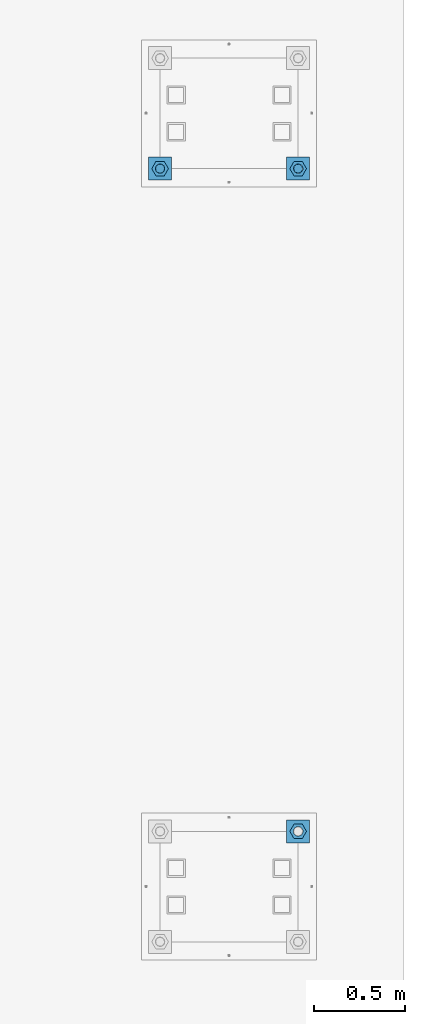
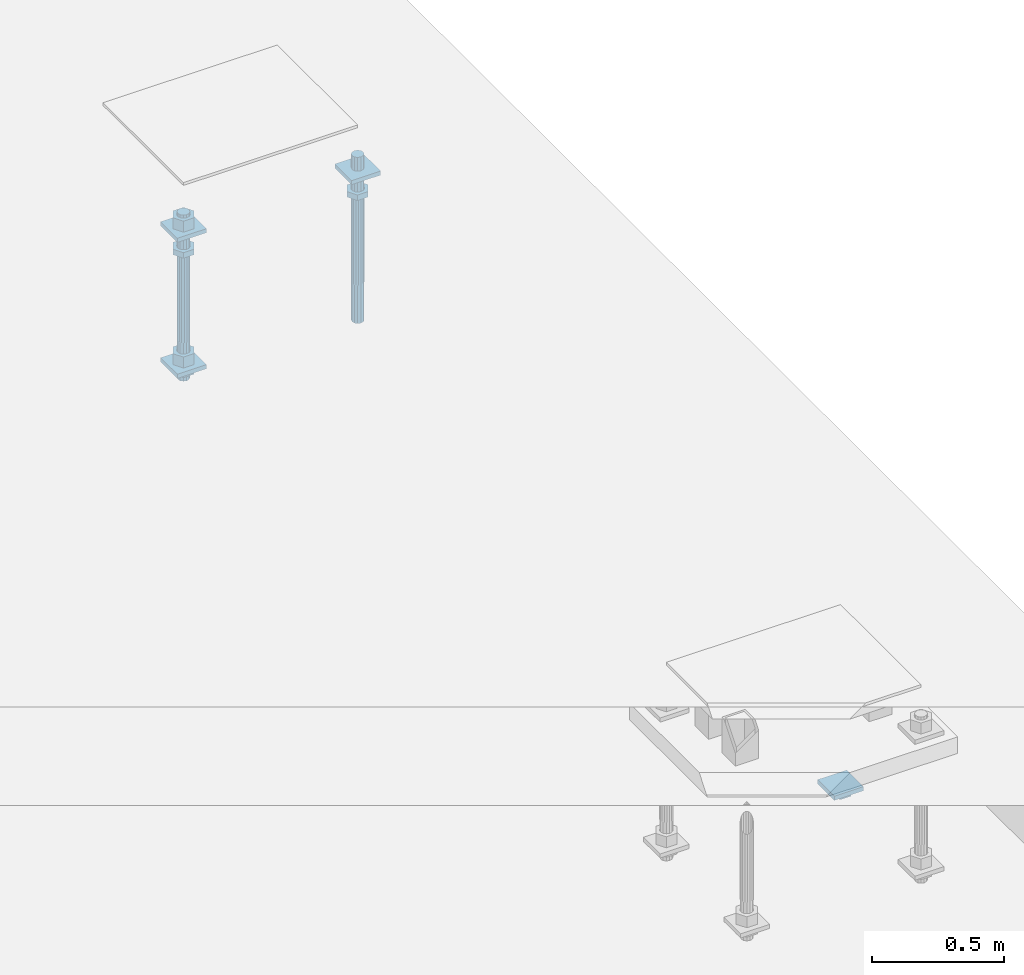
# One storey, part 2636 of 3843: 12 beams, 2 elements without a shape of their own.
"""IFC2X3 building model written with IfcOpenShell, lengths in millimetres."""

from ifc_helpers import new_model, si_unit, frame, origin_with_axes, place, context, subcontext, project, spatial, faceted_brep, material, type_object, element, aggregate, save


model = new_model("IFC2X3")

# Units and contexts
model_context = context("Model", 3, precision=1e-05, world=origin_with_axes())
body_context = subcontext(model_context, "Body", "Model", "MODEL_VIEW")
ifc_project = project(units=[si_unit("LENGTHUNIT", "METRE", prefix="MILLI"), si_unit("AREAUNIT", "SQUARE_METRE"), si_unit("VOLUMEUNIT", "CUBIC_METRE"), si_unit("MASSUNIT", "GRAM", prefix="KILO"), si_unit("TIMEUNIT", "SECOND"), si_unit("PLANEANGLEUNIT", "RADIAN"), si_unit("SOLIDANGLEUNIT", "STERADIAN"), si_unit("THERMODYNAMICTEMPERATUREUNIT", "DEGREE_CELSIUS"), si_unit("LUMINOUSINTENSITYUNIT", "LUMEN")], contexts=[model_context])

# Site, building, storey
site_placement = place(None, origin_with_axes())
site = spatial("IfcSite", under=ifc_project, at=site_placement, CompositionType="ELEMENT")
building_placement = place(site_placement, origin_with_axes())
building = spatial("IfcBuilding", under=site, at=building_placement, Name="Undefined", CompositionType="ELEMENT")
storey_placement = place(building_placement, origin_with_axes())
storey = spatial("IfcBuildingStorey", under=building, at=storey_placement, Name="Undefined", CompositionType="ELEMENT", Elevation=0.0)

# Assembly, beams
assembly_1_placement = place(storey_placement, origin_with_axes())
assembly_1 = element("IfcElementAssembly", 1, at=assembly_1_placement, inside=storey, Name="TEMPLATE", AssemblyPlace="NOTDEFINED", PredefinedType="RIGID_FRAME")
ifc_material_1 = material(Name="STEEL/A572-50")
beam_type_1 = type_object("IfcBeamType", PredefinedType="NOTDEFINED")
beam_1_placement = place(assembly_1_placement, frame((118465.6, 7086.60000152587, 29873.575), z_axis=(1.0, 0.0, 0.0), x_axis=(0.0, 1.0, 0.0)))
beam_1 = element("IfcBeam", 2, at=beam_1_placement, type_object=beam_type_1, material=ifc_material_1, Name="WASHER_PLATE", context=body_context, shape_type="Brep", body=[
    faceted_brep([(0.0, 9.52500000000146, -63.5), (0.0, 9.52500000000146, 63.5), (127.0, 9.52500000000146, 63.5), (127.0, 9.52500000000146, -63.5), (0.0, -9.52500000000146, 63.5), (127.0, -9.52500000000146, 63.5), (0.0, -9.52500000000146, -63.5), (127.0, -9.52500000000146, -63.5)], [[[0, 1, 2, 3]], [[1, 4, 5, 2]], [[4, 6, 7, 5]], [[6, 0, 3, 7]], [[5, 7, 3, 2]], [[6, 4, 1, 0]]]),
])
beam_2_placement = place(assembly_1_placement, frame((119227.6, 7086.60000152587, 29873.575), z_axis=(1.0, 0.0, 0.0), x_axis=(0.0, 1.0, 0.0)))
beam_2 = element("IfcBeam", 3, at=beam_2_placement, type_object=beam_type_1, material=ifc_material_1, Name="WASHER_PLATE", context=body_context, shape_type="Brep", body=[
    faceted_brep([(0.0, 9.52500000000146, -63.5), (0.0, 9.52500000000146, 63.5), (127.0, 9.52500000000146, 63.5), (127.0, 9.52500000000146, -63.5), (0.0, -9.52500000000146, 63.5), (127.0, -9.52500000000146, 63.5), (0.0, -9.52500000000146, -63.5), (127.0, -9.52500000000146, -63.5)], [[[0, 1, 2, 3]], [[1, 4, 5, 2]], [[4, 6, 7, 5]], [[6, 0, 3, 7]], [[5, 7, 3, 2]], [[6, 4, 1, 0]]]),
])
beam_3_placement = place(assembly_1_placement, frame((118465.6, 7086.60000152587, 29244.925), z_axis=(1.0, 0.0, 0.0), x_axis=(0.0, 1.0, 0.0)))
beam_3 = element("IfcBeam", 4, at=beam_3_placement, type_object=beam_type_1, material=ifc_material_1, Name="WASHER_PLATE", context=body_context, shape_type="Brep", body=[
    faceted_brep([(0.0, 9.52500000000146, -63.5), (0.0, 9.52500000000146, 63.5), (127.0, 9.52500000000146, 63.5), (127.0, 9.52500000000146, -63.5), (0.0, -9.52500000000146, 63.5), (127.0, -9.52500000000146, 63.5), (0.0, -9.52500000000146, -63.5), (127.0, -9.52500000000146, -63.5)], [[[0, 1, 2, 3]], [[1, 4, 5, 2]], [[4, 6, 7, 5]], [[6, 0, 3, 7]], [[5, 7, 3, 2]], [[6, 4, 1, 0]]]),
])

# Assembly, beam
assembly_2_placement = place(storey_placement, origin_with_axes())
assembly_2 = element("IfcElementAssembly", 5, at=assembly_2_placement, inside=storey, Name="TEMPLATE", AssemblyPlace="NOTDEFINED", PredefinedType="RIGID_FRAME")
beam_4_placement = place(assembly_2_placement, frame((119227.6, 3429.00000152587, 29244.925), z_axis=(1.0, 0.0, 0.0), x_axis=(0.0, 1.0, 0.0)))
beam_4 = element("IfcBeam", 6, at=beam_4_placement, type_object=beam_type_1, material=ifc_material_1, Name="WASHER_PLATE", context=body_context, shape_type="Brep", body=[
    faceted_brep([(0.0, 9.52500000000146, -63.5), (0.0, 9.52500000000146, 63.5), (127.0, 9.52500000000146, 63.5), (127.0, 9.52500000000146, -63.5), (0.0, -9.52500000000146, 63.5), (127.0, -9.52500000000146, 63.5), (0.0, -9.52500000000146, -63.5), (127.0, -9.52500000000146, -63.5)], [[[0, 1, 2, 3]], [[1, 4, 5, 2]], [[4, 6, 7, 5]], [[6, 0, 3, 7]], [[5, 7, 3, 2]], [[6, 4, 1, 0]]]),
])

# Beam
ifc_material_2 = material(Name="STEEL/A36")
beam_type_2 = type_object("IfcBeamType", Name="2_HALF_NUT", PredefinedType="NOTDEFINED")
beam_5_placement = place(assembly_1_placement, frame((118465.6, 7150.10000152587, 29787.85), z_axis=(0.0, 1.0, 0.0), x_axis=(0.0, 0.0, -1.0)))
beam_5 = element("IfcBeam", 7, at=beam_5_placement, type_object=beam_type_2, material=ifc_material_2, Name="NUT", ObjectType="2_HALF_NUT", context=body_context, shape_type="Brep", body=[
    faceted_brep([(0.0, -46.0369987487793, 0.0), (0.0, -23.0184993743896, -39.869213104248), (25.4000000000015, -23.0184993743896, -39.869213104248), (25.4000000000015, -46.0369987487793, 0.0), (0.0, 23.0184993743896, -39.869213104248), (25.4000000000015, 23.0184993743896, -39.869213104248), (0.0, 46.0369987487793, 0.0), (25.4000000000015, 46.0369987487793, 0.0), (0.0, 23.0184993743896, 39.869213104248), (25.4000000000015, 23.0184993743896, 39.869213104248), (0.0, -23.0184993743896, 39.869213104248), (25.4000000000015, -23.0184993743896, 39.869213104248), (0.0, 0.0, 26.1940002441406), (0.0, 11.3650617044477, 23.5999013092805), (25.4000000000015, 11.3650617044477, 23.5999013092805), (25.4000000000015, 0.0, 26.1940002441406), (0.0, 20.4791109456419, 16.3316083006721), (25.4000000000015, 20.4791109456419, 16.3316083006721), (0.0, 25.5370200498292, 5.82867859874386), (25.4000000000015, 25.5370200498292, 5.82867859874386), (0.0, 25.5370200498292, -5.82867859874386), (25.4000000000015, 25.5370200498292, -5.82867859874386), (0.0, 20.4791109456419, -16.3316083006721), (25.4000000000015, 20.4791109456419, -16.3316083006721), (0.0, 11.3650617044477, -23.5999013092805), (25.4000000000015, 11.3650617044477, -23.5999013092805), (0.0, 0.0, -26.1940002441406), (25.4000000000015, 0.0, -26.1940002441406), (0.0, -11.3650617044477, -23.5999013092805), (25.4000000000015, -11.3650617044477, -23.5999013092805), (0.0, -20.4791109456419, -16.3316083006721), (25.4000000000015, -20.4791109456419, -16.3316083006721), (0.0, -25.5370200498292, -5.82867859874386), (25.4000000000015, -25.5370200498292, -5.82867859874386), (0.0, -25.5370200498292, 5.82867859874386), (25.4000000000015, -25.5370200498292, 5.82867859874386), (0.0, -20.4791109456419, 16.3316083006721), (25.4000000000015, -20.4791109456419, 16.3316083006721), (0.0, -11.3650617044477, 23.5999013092805), (25.4000000000015, -11.3650617044477, 23.5999013092805)], [[[0, 1, 2, 3]], [[1, 4, 5, 2]], [[4, 6, 7, 5]], [[6, 8, 9, 7]], [[8, 10, 11, 9]], [[10, 0, 3, 11]], [[12, 13, 14, 15]], [[13, 16, 17, 14]], [[16, 18, 19, 17]], [[18, 20, 21, 19]], [[20, 22, 23, 21]], [[22, 24, 25, 23]], [[24, 26, 27, 25]], [[26, 28, 29, 27]], [[28, 30, 31, 29]], [[30, 32, 33, 31]], [[32, 34, 35, 33]], [[34, 36, 37, 35]], [[36, 38, 39, 37]], [[38, 12, 15, 39]], [[5, 7, 9, 11, 3, 2], [17, 19, 21, 23, 25, 27, 29, 31, 33, 35, 37, 39, 15, 14]], [[10, 8, 6, 4, 1, 0], [38, 36, 34, 32, 30, 28, 26, 24, 22, 20, 18, 16, 13, 12]]]),
])

beam_6_placement = place(assembly_1_placement, frame((118465.6, 7150.10000152587, 29235.4), z_axis=(0.0, 1.0, 0.0), x_axis=(0.0, 0.0, -1.0)))
beam_6 = element("IfcBeam", 8, at=beam_6_placement, type_object=beam_type_2, material=ifc_material_2, Name="NUT", ObjectType="2_HALF_NUT", context=body_context, shape_type="Brep", body=[
    faceted_brep([(0.0, -46.0369987487793, 0.0), (0.0, -23.0184993743896, -39.869213104248), (25.4000000000015, -23.0184993743896, -39.869213104248), (25.4000000000015, -46.0369987487793, 0.0), (0.0, 23.0184993743896, -39.869213104248), (25.4000000000015, 23.0184993743896, -39.869213104248), (0.0, 46.0369987487793, 0.0), (25.4000000000015, 46.0369987487793, 0.0), (0.0, 23.0184993743896, 39.869213104248), (25.4000000000015, 23.0184993743896, 39.869213104248), (0.0, -23.0184993743896, 39.869213104248), (25.4000000000015, -23.0184993743896, 39.869213104248), (0.0, 0.0, 26.1940002441406), (0.0, 11.3650617044477, 23.5999013092805), (25.4000000000015, 11.3650617044477, 23.5999013092805), (25.4000000000015, 0.0, 26.1940002441406), (0.0, 20.4791109456419, 16.3316083006721), (25.4000000000015, 20.4791109456419, 16.3316083006721), (0.0, 25.5370200498292, 5.82867859874386), (25.4000000000015, 25.5370200498292, 5.82867859874386), (0.0, 25.5370200498292, -5.82867859874386), (25.4000000000015, 25.5370200498292, -5.82867859874386), (0.0, 20.4791109456419, -16.3316083006721), (25.4000000000015, 20.4791109456419, -16.3316083006721), (0.0, 11.3650617044477, -23.5999013092805), (25.4000000000015, 11.3650617044477, -23.5999013092805), (0.0, 0.0, -26.1940002441406), (25.4000000000015, 0.0, -26.1940002441406), (0.0, -11.3650617044477, -23.5999013092805), (25.4000000000015, -11.3650617044477, -23.5999013092805), (0.0, -20.4791109456419, -16.3316083006721), (25.4000000000015, -20.4791109456419, -16.3316083006721), (0.0, -25.5370200498292, -5.82867859874386), (25.4000000000015, -25.5370200498292, -5.82867859874386), (0.0, -25.5370200498292, 5.82867859874386), (25.4000000000015, -25.5370200498292, 5.82867859874386), (0.0, -20.4791109456419, 16.3316083006721), (25.4000000000015, -20.4791109456419, 16.3316083006721), (0.0, -11.3650617044477, 23.5999013092805), (25.4000000000015, -11.3650617044477, 23.5999013092805)], [[[0, 1, 2, 3]], [[1, 4, 5, 2]], [[4, 6, 7, 5]], [[6, 8, 9, 7]], [[8, 10, 11, 9]], [[10, 0, 3, 11]], [[12, 13, 14, 15]], [[13, 16, 17, 14]], [[16, 18, 19, 17]], [[18, 20, 21, 19]], [[20, 22, 23, 21]], [[22, 24, 25, 23]], [[24, 26, 27, 25]], [[26, 28, 29, 27]], [[28, 30, 31, 29]], [[30, 32, 33, 31]], [[32, 34, 35, 33]], [[34, 36, 37, 35]], [[36, 38, 39, 37]], [[38, 12, 15, 39]], [[5, 7, 9, 11, 3, 2], [17, 19, 21, 23, 25, 27, 29, 31, 33, 35, 37, 39, 15, 14]], [[10, 8, 6, 4, 1, 0], [38, 36, 34, 32, 30, 28, 26, 24, 22, 20, 18, 16, 13, 12]]]),
])

beam_7_placement = place(assembly_1_placement, frame((119227.6, 7150.10000152587, 29787.85), z_axis=(0.0, 1.0, 0.0), x_axis=(0.0, 0.0, -1.0)))
beam_7 = element("IfcBeam", 9, at=beam_7_placement, type_object=beam_type_2, material=ifc_material_2, Name="NUT", ObjectType="2_HALF_NUT", context=body_context, shape_type="Brep", body=[
    faceted_brep([(0.0, -46.0369987487793, 0.0), (0.0, -23.0184993743896, -39.869213104248), (25.4000000000015, -23.0184993743896, -39.869213104248), (25.4000000000015, -46.0369987487793, 0.0), (0.0, 23.0184993743896, -39.869213104248), (25.4000000000015, 23.0184993743896, -39.869213104248), (0.0, 46.0369987487793, 0.0), (25.4000000000015, 46.0369987487793, 0.0), (0.0, 23.0184993743896, 39.869213104248), (25.4000000000015, 23.0184993743896, 39.869213104248), (0.0, -23.0184993743896, 39.869213104248), (25.4000000000015, -23.0184993743896, 39.869213104248), (0.0, 0.0, 26.1940002441406), (0.0, 11.3650617044477, 23.5999013092805), (25.4000000000015, 11.3650617044477, 23.5999013092805), (25.4000000000015, 0.0, 26.1940002441406), (0.0, 20.4791109456419, 16.3316083006721), (25.4000000000015, 20.4791109456419, 16.3316083006721), (0.0, 25.5370200498292, 5.82867859874386), (25.4000000000015, 25.5370200498292, 5.82867859874386), (0.0, 25.5370200498292, -5.82867859874386), (25.4000000000015, 25.5370200498292, -5.82867859874386), (0.0, 20.4791109456419, -16.3316083006721), (25.4000000000015, 20.4791109456419, -16.3316083006721), (0.0, 11.3650617044477, -23.5999013092805), (25.4000000000015, 11.3650617044477, -23.5999013092805), (0.0, 0.0, -26.1940002441406), (25.4000000000015, 0.0, -26.1940002441406), (0.0, -11.3650617044477, -23.5999013092805), (25.4000000000015, -11.3650617044477, -23.5999013092805), (0.0, -20.4791109456419, -16.3316083006721), (25.4000000000015, -20.4791109456419, -16.3316083006721), (0.0, -25.5370200498292, -5.82867859874386), (25.4000000000015, -25.5370200498292, -5.82867859874386), (0.0, -25.5370200498292, 5.82867859874386), (25.4000000000015, -25.5370200498292, 5.82867859874386), (0.0, -20.4791109456419, 16.3316083006721), (25.4000000000015, -20.4791109456419, 16.3316083006721), (0.0, -11.3650617044477, 23.5999013092805), (25.4000000000015, -11.3650617044477, 23.5999013092805)], [[[0, 1, 2, 3]], [[1, 4, 5, 2]], [[4, 6, 7, 5]], [[6, 8, 9, 7]], [[8, 10, 11, 9]], [[10, 0, 3, 11]], [[12, 13, 14, 15]], [[13, 16, 17, 14]], [[16, 18, 19, 17]], [[18, 20, 21, 19]], [[20, 22, 23, 21]], [[22, 24, 25, 23]], [[24, 26, 27, 25]], [[26, 28, 29, 27]], [[28, 30, 31, 29]], [[30, 32, 33, 31]], [[32, 34, 35, 33]], [[34, 36, 37, 35]], [[36, 38, 39, 37]], [[38, 12, 15, 39]], [[5, 7, 9, 11, 3, 2], [17, 19, 21, 23, 25, 27, 29, 31, 33, 35, 37, 39, 15, 14]], [[10, 8, 6, 4, 1, 0], [38, 36, 34, 32, 30, 28, 26, 24, 22, 20, 18, 16, 13, 12]]]),
])

beam_8_placement = place(assembly_2_placement, frame((119227.6, 3492.50000152587, 29235.4), z_axis=(0.0, 1.0, 0.0), x_axis=(0.0, 0.0, -1.0)))
beam_8 = element("IfcBeam", 10, at=beam_8_placement, type_object=beam_type_2, material=ifc_material_2, Name="NUT", ObjectType="2_HALF_NUT", context=body_context, shape_type="Brep", body=[
    faceted_brep([(0.0, -46.0369987487793, 0.0), (0.0, -23.0184993743896, -39.869213104248), (25.4000000000015, -23.0184993743896, -39.869213104248), (25.4000000000015, -46.0369987487793, 0.0), (0.0, 23.0184993743896, -39.869213104248), (25.4000000000015, 23.0184993743896, -39.869213104248), (0.0, 46.0369987487793, 0.0), (25.4000000000015, 46.0369987487793, 0.0), (0.0, 23.0184993743896, 39.869213104248), (25.4000000000015, 23.0184993743896, 39.869213104248), (0.0, -23.0184993743896, 39.869213104248), (25.4000000000015, -23.0184993743896, 39.869213104248), (0.0, 0.0, 26.1940002441406), (0.0, 11.3650617044477, 23.5999013092805), (25.4000000000015, 11.3650617044477, 23.5999013092805), (25.4000000000015, 0.0, 26.1940002441406), (0.0, 20.4791109456419, 16.3316083006721), (25.4000000000015, 20.4791109456419, 16.3316083006721), (0.0, 25.5370200498292, 5.82867859874386), (25.4000000000015, 25.5370200498292, 5.82867859874386), (0.0, 25.5370200498292, -5.82867859874386), (25.4000000000015, 25.5370200498292, -5.82867859874386), (0.0, 20.4791109456419, -16.3316083006721), (25.4000000000015, 20.4791109456419, -16.3316083006721), (0.0, 11.3650617044477, -23.5999013092805), (25.4000000000015, 11.3650617044477, -23.5999013092805), (0.0, 0.0, -26.1940002441406), (25.4000000000015, 0.0, -26.1940002441406), (0.0, -11.3650617044477, -23.5999013092805), (25.4000000000015, -11.3650617044477, -23.5999013092805), (0.0, -20.4791109456419, -16.3316083006721), (25.4000000000015, -20.4791109456419, -16.3316083006721), (0.0, -25.5370200498292, -5.82867859874386), (25.4000000000015, -25.5370200498292, -5.82867859874386), (0.0, -25.5370200498292, 5.82867859874386), (25.4000000000015, -25.5370200498292, 5.82867859874386), (0.0, -20.4791109456419, 16.3316083006721), (25.4000000000015, -20.4791109456419, 16.3316083006721), (0.0, -11.3650617044477, 23.5999013092805), (25.4000000000015, -11.3650617044477, 23.5999013092805)], [[[0, 1, 2, 3]], [[1, 4, 5, 2]], [[4, 6, 7, 5]], [[6, 8, 9, 7]], [[8, 10, 11, 9]], [[10, 0, 3, 11]], [[12, 13, 14, 15]], [[13, 16, 17, 14]], [[16, 18, 19, 17]], [[18, 20, 21, 19]], [[20, 22, 23, 21]], [[22, 24, 25, 23]], [[24, 26, 27, 25]], [[26, 28, 29, 27]], [[28, 30, 31, 29]], [[30, 32, 33, 31]], [[32, 34, 35, 33]], [[34, 36, 37, 35]], [[36, 38, 39, 37]], [[38, 12, 15, 39]], [[5, 7, 9, 11, 3, 2], [17, 19, 21, 23, 25, 27, 29, 31, 33, 35, 37, 39, 15, 14]], [[10, 8, 6, 4, 1, 0], [38, 36, 34, 32, 30, 28, 26, 24, 22, 20, 18, 16, 13, 12]]]),
])

aggregate(assembly_2, [beam_8, beam_4])

beam_type_3 = type_object("IfcBeamType", Name="2_HEAVY_HEX_NUT", PredefinedType="NOTDEFINED")
beam_9_placement = place(assembly_1_placement, frame((118465.6, 7150.10000152587, 29933.9), z_axis=(0.0, 1.0, 0.0), x_axis=(0.0, 0.0, -1.0)))
beam_9 = element("IfcBeam", 11, at=beam_9_placement, type_object=beam_type_3, material=ifc_material_2, Name="NUT", ObjectType="2_HEAVY_HEX_NUT", context=body_context, shape_type="Brep", body=[
    faceted_brep([(0.0, -46.0369987487793, 0.0), (0.0, -23.0184993743896, -39.869213104248), (50.7999999999993, -23.0184993743896, -39.869213104248), (50.7999999999993, -46.0369987487793, 0.0), (0.0, 23.0184993743896, -39.869213104248), (50.7999999999993, 23.0184993743896, -39.869213104248), (0.0, 46.0369987487793, 0.0), (50.7999999999993, 46.0369987487793, 0.0), (0.0, 23.0184993743896, 39.869213104248), (50.7999999999993, 23.0184993743896, 39.869213104248), (0.0, -23.0184993743896, 39.869213104248), (50.7999999999993, -23.0184993743896, 39.869213104248), (0.0, 0.0, 26.1940002441406), (0.0, 11.3650617044477, 23.5999013092805), (50.7999999999993, 11.3650617044477, 23.5999013092805), (50.7999999999993, 0.0, 26.1940002441406), (0.0, 20.4791109456419, 16.3316083006721), (50.7999999999993, 20.4791109456419, 16.3316083006721), (0.0, 25.5370200498292, 5.82867859874386), (50.7999999999993, 25.5370200498292, 5.82867859874386), (0.0, 25.5370200498292, -5.82867859874386), (50.7999999999993, 25.5370200498292, -5.82867859874386), (0.0, 20.4791109456419, -16.3316083006721), (50.7999999999993, 20.4791109456419, -16.3316083006721), (0.0, 11.3650617044477, -23.5999013092805), (50.7999999999993, 11.3650617044477, -23.5999013092805), (0.0, 0.0, -26.1940002441406), (50.7999999999993, 0.0, -26.1940002441406), (0.0, -11.3650617044477, -23.5999013092805), (50.7999999999993, -11.3650617044477, -23.5999013092805), (0.0, -20.4791109456419, -16.3316083006721), (50.7999999999993, -20.4791109456419, -16.3316083006721), (0.0, -25.5370200498292, -5.82867859874386), (50.7999999999993, -25.5370200498292, -5.82867859874386), (0.0, -25.5370200498292, 5.82867859874386), (50.7999999999993, -25.5370200498292, 5.82867859874386), (0.0, -20.4791109456419, 16.3316083006721), (50.7999999999993, -20.4791109456419, 16.3316083006721), (0.0, -11.3650617044477, 23.5999013092805), (50.7999999999993, -11.3650617044477, 23.5999013092805)], [[[0, 1, 2, 3]], [[1, 4, 5, 2]], [[4, 6, 7, 5]], [[6, 8, 9, 7]], [[8, 10, 11, 9]], [[10, 0, 3, 11]], [[12, 13, 14, 15]], [[13, 16, 17, 14]], [[16, 18, 19, 17]], [[18, 20, 21, 19]], [[20, 22, 23, 21]], [[22, 24, 25, 23]], [[24, 26, 27, 25]], [[26, 28, 29, 27]], [[28, 30, 31, 29]], [[30, 32, 33, 31]], [[32, 34, 35, 33]], [[34, 36, 37, 35]], [[36, 38, 39, 37]], [[38, 12, 15, 39]], [[5, 7, 9, 11, 3, 2], [17, 19, 21, 23, 25, 27, 29, 31, 33, 35, 37, 39, 15, 14]], [[10, 8, 6, 4, 1, 0], [38, 36, 34, 32, 30, 28, 26, 24, 22, 20, 18, 16, 13, 12]]]),
])

beam_10_placement = place(assembly_1_placement, frame((118465.6, 7150.10000152587, 29305.25), z_axis=(0.0, 1.0, 0.0), x_axis=(0.0, 0.0, -1.0)))
beam_10 = element("IfcBeam", 12, at=beam_10_placement, type_object=beam_type_3, material=ifc_material_2, Name="NUT", ObjectType="2_HEAVY_HEX_NUT", context=body_context, shape_type="Brep", body=[
    faceted_brep([(0.0, -46.0369987487793, 0.0), (0.0, -23.0184993743896, -39.869213104248), (50.7999999999993, -23.0184993743896, -39.869213104248), (50.7999999999993, -46.0369987487793, 0.0), (0.0, 23.0184993743896, -39.869213104248), (50.7999999999993, 23.0184993743896, -39.869213104248), (0.0, 46.0369987487793, 0.0), (50.7999999999993, 46.0369987487793, 0.0), (0.0, 23.0184993743896, 39.869213104248), (50.7999999999993, 23.0184993743896, 39.869213104248), (0.0, -23.0184993743896, 39.869213104248), (50.7999999999993, -23.0184993743896, 39.869213104248), (0.0, 0.0, 26.1940002441406), (0.0, 11.3650617044477, 23.5999013092805), (50.7999999999993, 11.3650617044477, 23.5999013092805), (50.7999999999993, 0.0, 26.1940002441406), (0.0, 20.4791109456419, 16.3316083006721), (50.7999999999993, 20.4791109456419, 16.3316083006721), (0.0, 25.5370200498292, 5.82867859874386), (50.7999999999993, 25.5370200498292, 5.82867859874386), (0.0, 25.5370200498292, -5.82867859874386), (50.7999999999993, 25.5370200498292, -5.82867859874386), (0.0, 20.4791109456419, -16.3316083006721), (50.7999999999993, 20.4791109456419, -16.3316083006721), (0.0, 11.3650617044477, -23.5999013092805), (50.7999999999993, 11.3650617044477, -23.5999013092805), (0.0, 0.0, -26.1940002441406), (50.7999999999993, 0.0, -26.1940002441406), (0.0, -11.3650617044477, -23.5999013092805), (50.7999999999993, -11.3650617044477, -23.5999013092805), (0.0, -20.4791109456419, -16.3316083006721), (50.7999999999993, -20.4791109456419, -16.3316083006721), (0.0, -25.5370200498292, -5.82867859874386), (50.7999999999993, -25.5370200498292, -5.82867859874386), (0.0, -25.5370200498292, 5.82867859874386), (50.7999999999993, -25.5370200498292, 5.82867859874386), (0.0, -20.4791109456419, 16.3316083006721), (50.7999999999993, -20.4791109456419, 16.3316083006721), (0.0, -11.3650617044477, 23.5999013092805), (50.7999999999993, -11.3650617044477, 23.5999013092805)], [[[0, 1, 2, 3]], [[1, 4, 5, 2]], [[4, 6, 7, 5]], [[6, 8, 9, 7]], [[8, 10, 11, 9]], [[10, 0, 3, 11]], [[12, 13, 14, 15]], [[13, 16, 17, 14]], [[16, 18, 19, 17]], [[18, 20, 21, 19]], [[20, 22, 23, 21]], [[22, 24, 25, 23]], [[24, 26, 27, 25]], [[26, 28, 29, 27]], [[28, 30, 31, 29]], [[30, 32, 33, 31]], [[32, 34, 35, 33]], [[34, 36, 37, 35]], [[36, 38, 39, 37]], [[38, 12, 15, 39]], [[5, 7, 9, 11, 3, 2], [17, 19, 21, 23, 25, 27, 29, 31, 33, 35, 37, 39, 15, 14]], [[10, 8, 6, 4, 1, 0], [38, 36, 34, 32, 30, 28, 26, 24, 22, 20, 18, 16, 13, 12]]]),
])

ifc_material_3 = material()
beam_type_4 = type_object("IfcBeamType", PredefinedType="NOTDEFINED")
beam_11_placement = place(assembly_1_placement, frame((118465.600001526, 7150.09999999998, 29762.45), z_axis=(1.0, 0.0, 0.0), x_axis=(0.0, 0.0, -1.0)))
beam_11 = element("IfcBeam", 13, at=beam_11_placement, type_object=beam_type_4, material=ifc_material_3, Name="ANCHOR_ROD", context=body_context, shape_type="Brep", body=[
    faceted_brep([(0.0, -23.4665401257807, -9.72015918207035), (0.0, -17.9605122421344, -17.9605122421417), (406.399999999998, -17.9605122421344, -17.9605122421417), (406.399999999998, -23.4665401257807, -9.72015918207035), (0.0, -9.72015918207762, -23.466540125788), (406.399999999998, -9.72015918207762, -23.466540125788), (0.0, 0.0, -25.4000000000015), (406.399999999998, 0.0, -25.4000000000015), (0.0, 9.72015918207762, -23.466540125788), (406.399999999998, 9.72015918207762, -23.466540125788), (0.0, 17.9605122421344, -17.9605122421417), (406.399999999998, 17.9605122421344, -17.9605122421417), (0.0, 23.4665401257807, -9.72015918207035), (406.399999999998, 23.4665401257807, -9.72015918207035), (0.0, 25.3999996185303, 0.0), (406.399999999998, 25.3999999999942, 0.0), (0.0, 23.4665401257807, 9.72015918207035), (406.399999999998, 23.4665401257807, 9.72015918207035), (0.0, 17.9605122421344, 17.9605122421417), (406.399999999998, 17.9605122421344, 17.9605122421417), (0.0, 9.72015918207762, 23.466540125788), (406.399999999998, 9.72015918207762, 23.466540125788), (0.0, 0.0, 25.4000000000015), (406.399999999998, 0.0, 25.4000000000015), (0.0, -9.72015918207762, 23.466540125788), (406.399999999998, -9.72015918207762, 23.466540125788), (0.0, -17.9605122421344, 17.9605122421417), (406.399999999998, -17.9605122421344, 17.9605122421417), (0.0, -23.4665401257807, 9.72015918207035), (406.399999999998, -23.4665401257807, 9.72015918207035), (0.0, -25.3999996185303, 0.0), (406.399999999998, -25.3999999999942, 0.0), (584.200000000001, -12.2499999999854, -21.2176223927163), (584.200000000001, 1.45519152283669e-11, -24.5), (584.200000000001, 12.2500000000146, -21.2176223927163), (584.200000000001, 21.2176223927381, -12.25), (584.200000000001, 24.5000000000146, 0.0), (584.200000000001, 21.2176223927381, 12.25), (584.200000000001, 12.2500000000146, 21.2176223927163), (584.200000000001, 1.45519152283669e-11, 24.5), (584.200000000001, -12.2499999999854, 21.2176223927163), (584.200000000001, -21.217622392709, 12.25), (584.200000000001, -24.4999999999854, 0.0), (584.200000000001, -21.217622392709, -12.25), (406.399999999998, -24.4999999999854, 0.0), (406.399999999998, -21.217622392709, -12.25), (406.399999999998, -12.2499999999854, -21.2176223927163), (406.399999999998, 1.45519152283669e-11, -24.5), (406.399999999998, 12.2500000000146, -21.2176223927163), (406.399999999998, 21.2176223927381, -12.25), (406.399999999998, 24.5000000000146, 0.0), (406.399999999998, 21.2176223927381, 12.25), (406.399999999998, 12.2500000000146, 21.2176223927163), (406.399999999998, 1.45519152283669e-11, 24.5), (406.399999999998, -12.2499999999854, 21.2176223927163), (406.399999999998, -21.217622392709, 12.25), (0.0, 12.2500000000146, 21.2176223927163), (0.0, 1.45519152283669e-11, 24.5), (0.0, -12.2499999999854, 21.2176223927163), (0.0, -21.217622392709, 12.25), (0.0, -24.4999999999854, 0.0), (0.0, -21.217622392709, -12.25), (0.0, -12.2499999999854, -21.2176223927163), (0.0, 1.45519152283669e-11, -24.5), (0.0, 12.2500000000146, -21.2176223927163), (0.0, 21.2176223927381, -12.25), (0.0, 24.5000000000146, 0.0), (0.0, 21.2176223927381, 12.25), (-184.150000000001, -21.217622392709, 12.25), (-184.150000000001, -12.2499999999854, 21.2176223927163), (-184.150000000001, 1.45519152283669e-11, 24.5), (-184.150000000001, 12.2500000000146, 21.2176223927163), (-184.150000000001, 21.2176223927381, 12.25), (-184.150000000001, 24.5000000000146, 0.0), (-184.150000000001, 21.2176223927381, -12.25), (-184.150000000001, 12.2500000000146, -21.2176223927163), (-184.150000000001, 1.45519152283669e-11, -24.5), (-184.150000000001, -12.2499999999854, -21.2176223927163), (-184.150000000001, -21.217622392709, -12.25), (-184.150000000001, -24.4999999999854, 0.0)], [[[0, 1, 2, 3]], [[1, 4, 5, 2]], [[4, 6, 7, 5]], [[6, 8, 9, 7]], [[8, 10, 11, 9]], [[10, 12, 13, 11]], [[12, 14, 15, 13]], [[14, 16, 17, 15]], [[16, 18, 19, 17]], [[18, 20, 21, 19]], [[20, 22, 23, 21]], [[22, 24, 25, 23]], [[24, 26, 27, 25]], [[26, 28, 29, 27]], [[28, 30, 31, 29]], [[32, 33, 34, 35, 36, 37, 38, 39, 40, 41, 42, 43]], [[43, 42, 44, 45]], [[32, 43, 45, 46]], [[33, 32, 46, 47]], [[34, 33, 47, 48]], [[35, 34, 48, 49]], [[36, 35, 49, 50]], [[37, 36, 50, 51]], [[38, 37, 51, 52]], [[39, 38, 52, 53]], [[40, 39, 53, 54]], [[41, 40, 54, 55]], [[42, 41, 55, 44]], [[2, 5, 7, 9, 11, 13, 15, 17, 19, 21, 23, 25, 27, 29, 31, 3], [54, 53, 52, 51, 50, 49, 48, 47, 46, 45, 44, 55]], [[30, 0, 3, 31]], [[28, 26, 24, 22, 20, 18, 16, 14, 12, 10, 8, 6, 4, 1, 0, 30], [56, 57, 58, 59, 60, 61, 62, 63, 64, 65, 66, 67]], [[68, 69, 70, 71, 72, 73, 74, 75, 76, 77, 78, 79]], [[71, 70, 57, 56]], [[72, 71, 56, 67]], [[73, 72, 67, 66]], [[74, 73, 66, 65]], [[75, 74, 65, 64]], [[76, 75, 64, 63]], [[77, 76, 63, 62]], [[78, 77, 62, 61]], [[79, 78, 61, 60]], [[68, 79, 60, 59]], [[69, 68, 59, 58]], [[70, 69, 58, 57]]]),
])

beam_12_placement = place(assembly_1_placement, frame((119227.600001526, 7150.09999999998, 29762.45), z_axis=(1.0, 0.0, 0.0), x_axis=(0.0, 0.0, -1.0)))
beam_12 = element("IfcBeam", 14, at=beam_12_placement, type_object=beam_type_4, material=ifc_material_3, Name="ANCHOR_ROD", context=body_context, shape_type="Brep", body=[
    faceted_brep([(0.0, -23.4665401257807, -9.72015918207035), (0.0, -17.9605122421344, -17.9605122421417), (406.399999999998, -17.9605122421344, -17.9605122421417), (406.399999999998, -23.4665401257807, -9.72015918207035), (0.0, -9.72015918207762, -23.466540125788), (406.399999999998, -9.72015918207762, -23.466540125788), (0.0, 0.0, -25.4000000000015), (406.399999999998, 0.0, -25.4000000000015), (0.0, 9.72015918207762, -23.466540125788), (406.399999999998, 9.72015918207762, -23.466540125788), (0.0, 17.9605122421344, -17.9605122421417), (406.399999999998, 17.9605122421344, -17.9605122421417), (0.0, 23.4665401257807, -9.72015918207035), (406.399999999998, 23.4665401257807, -9.72015918207035), (0.0, 25.3999996185303, 0.0), (406.399999999998, 25.3999999999942, 0.0), (0.0, 23.4665401257807, 9.72015918207035), (406.399999999998, 23.4665401257807, 9.72015918207035), (0.0, 17.9605122421344, 17.9605122421417), (406.399999999998, 17.9605122421344, 17.9605122421417), (0.0, 9.72015918207762, 23.466540125788), (406.399999999998, 9.72015918207762, 23.466540125788), (0.0, 0.0, 25.4000000000015), (406.399999999998, 0.0, 25.4000000000015), (0.0, -9.72015918207762, 23.466540125788), (406.399999999998, -9.72015918207762, 23.466540125788), (0.0, -17.9605122421344, 17.9605122421417), (406.399999999998, -17.9605122421344, 17.9605122421417), (0.0, -23.4665401257807, 9.72015918207035), (406.399999999998, -23.4665401257807, 9.72015918207035), (0.0, -25.3999996185303, 0.0), (406.399999999998, -25.3999999999942, 0.0), (584.200000000001, -12.2499999999854, -21.2176223927163), (584.200000000001, 1.45519152283669e-11, -24.5), (584.200000000001, 12.2500000000146, -21.2176223927163), (584.200000000001, 21.2176223927381, -12.25), (584.200000000001, 24.5000000000146, 0.0), (584.200000000001, 21.2176223927381, 12.25), (584.200000000001, 12.2500000000146, 21.2176223927163), (584.200000000001, 1.45519152283669e-11, 24.5), (584.200000000001, -12.2499999999854, 21.2176223927163), (584.200000000001, -21.217622392709, 12.25), (584.200000000001, -24.4999999999854, 0.0), (584.200000000001, -21.217622392709, -12.25), (406.399999999998, -24.4999999999854, 0.0), (406.399999999998, -21.217622392709, -12.25), (406.399999999998, -12.2499999999854, -21.2176223927163), (406.399999999998, 1.45519152283669e-11, -24.5), (406.399999999998, 12.2500000000146, -21.2176223927163), (406.399999999998, 21.2176223927381, -12.25), (406.399999999998, 24.5000000000146, 0.0), (406.399999999998, 21.2176223927381, 12.25), (406.399999999998, 12.2500000000146, 21.2176223927163), (406.399999999998, 1.45519152283669e-11, 24.5), (406.399999999998, -12.2499999999854, 21.2176223927163), (406.399999999998, -21.217622392709, 12.25), (0.0, 12.2500000000146, 21.2176223927163), (0.0, 1.45519152283669e-11, 24.5), (0.0, -12.2499999999854, 21.2176223927163), (0.0, -21.217622392709, 12.25), (0.0, -24.4999999999854, 0.0), (0.0, -21.217622392709, -12.25), (0.0, -12.2499999999854, -21.2176223927163), (0.0, 1.45519152283669e-11, -24.5), (0.0, 12.2500000000146, -21.2176223927163), (0.0, 21.2176223927381, -12.25), (0.0, 24.5000000000146, 0.0), (0.0, 21.2176223927381, 12.25), (-184.150000000001, -21.217622392709, 12.25), (-184.150000000001, -12.2499999999854, 21.2176223927163), (-184.150000000001, 1.45519152283669e-11, 24.5), (-184.150000000001, 12.2500000000146, 21.2176223927163), (-184.150000000001, 21.2176223927381, 12.25), (-184.150000000001, 24.5000000000146, 0.0), (-184.150000000001, 21.2176223927381, -12.25), (-184.150000000001, 12.2500000000146, -21.2176223927163), (-184.150000000001, 1.45519152283669e-11, -24.5), (-184.150000000001, -12.2499999999854, -21.2176223927163), (-184.150000000001, -21.217622392709, -12.25), (-184.150000000001, -24.4999999999854, 0.0)], [[[0, 1, 2, 3]], [[1, 4, 5, 2]], [[4, 6, 7, 5]], [[6, 8, 9, 7]], [[8, 10, 11, 9]], [[10, 12, 13, 11]], [[12, 14, 15, 13]], [[14, 16, 17, 15]], [[16, 18, 19, 17]], [[18, 20, 21, 19]], [[20, 22, 23, 21]], [[22, 24, 25, 23]], [[24, 26, 27, 25]], [[26, 28, 29, 27]], [[28, 30, 31, 29]], [[32, 33, 34, 35, 36, 37, 38, 39, 40, 41, 42, 43]], [[43, 42, 44, 45]], [[32, 43, 45, 46]], [[33, 32, 46, 47]], [[34, 33, 47, 48]], [[35, 34, 48, 49]], [[36, 35, 49, 50]], [[37, 36, 50, 51]], [[38, 37, 51, 52]], [[39, 38, 52, 53]], [[40, 39, 53, 54]], [[41, 40, 54, 55]], [[42, 41, 55, 44]], [[2, 5, 7, 9, 11, 13, 15, 17, 19, 21, 23, 25, 27, 29, 31, 3], [54, 53, 52, 51, 50, 49, 48, 47, 46, 45, 44, 55]], [[30, 0, 3, 31]], [[28, 26, 24, 22, 20, 18, 16, 14, 12, 10, 8, 6, 4, 1, 0, 30], [56, 57, 58, 59, 60, 61, 62, 63, 64, 65, 66, 67]], [[68, 69, 70, 71, 72, 73, 74, 75, 76, 77, 78, 79]], [[71, 70, 57, 56]], [[72, 71, 56, 67]], [[73, 72, 67, 66]], [[74, 73, 66, 65]], [[75, 74, 65, 64]], [[76, 75, 64, 63]], [[77, 76, 63, 62]], [[78, 77, 62, 61]], [[79, 78, 61, 60]], [[68, 79, 60, 59]], [[69, 68, 59, 58]], [[70, 69, 58, 57]]]),
])

aggregate(assembly_1, [beam_11, beam_12, beam_1, beam_2, beam_5, beam_9, beam_10, beam_6, beam_3, beam_7])

save(model, "model.ifc")
